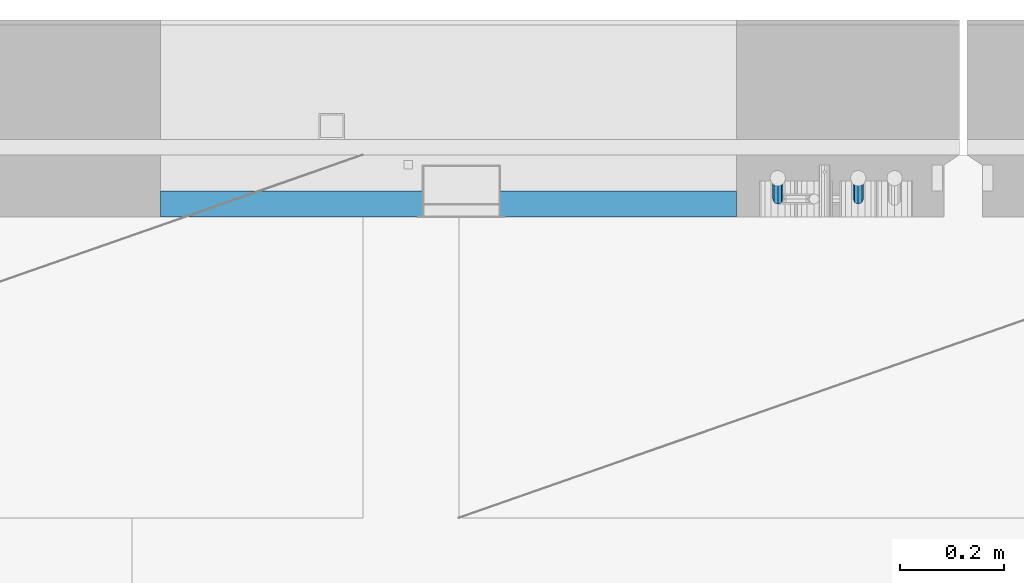
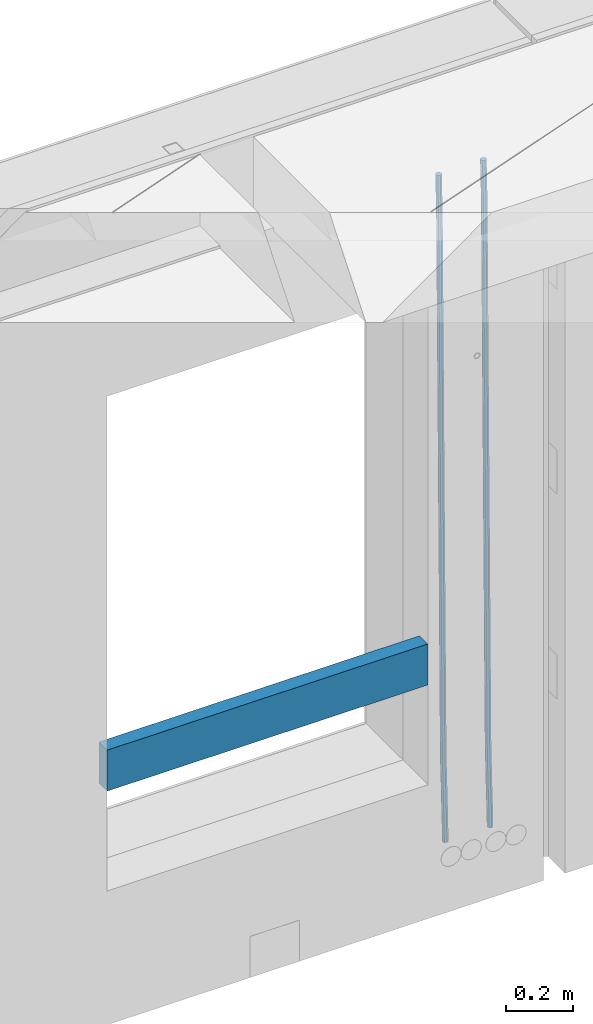
# One storey, part 112 of 341: 3 beams, 1 element without a shape of its own.
"""IFC2X3 building model written with IfcOpenShell, lengths in millimetres."""

import ifcopenshell
import ifcopenshell.guid

model = None  # the IFC model being written
_history = None  # IfcOwnerHistory: only IFC2X3 demands one
_inside = {}  # id of a spatial element -> (the spatial element, [elements in it])
_under = {}  # id of a project, library or spatial element -> (it, [spatial elements below it])
_declared = {}  # id of a project -> (the project, [libraries it declares])
_typed = {}  # id of a type object -> (the type object, [elements of that type])
_made_of = {}  # id of a material, layer set ... -> (it, [elements and type objects made of it])


def new_model(schema):
    """Start an empty IFC model of exactly this schema.

    Asked for "IFC4X3", IfcOpenShell would pick the latest addendum, in which some entities
    have other attributes; the version numbers below select the first issue.
    IFC2X3 requires an IfcOwnerHistory on every rooted entity: one is made here for all.
    """
    global model, _history
    if schema == "IFC4X3":
        model = ifcopenshell.file(schema_version=(4, 3, 0, 0))
    else:
        model = ifcopenshell.file(schema=schema)
    _inside.clear()
    _under.clear()
    _declared.clear()
    _typed.clear()
    _made_of.clear()
    _history = None
    if model.schema == "IFC2X3":
        org = make("IfcOrganization", Name="unknown")
        user = make(
            "IfcPersonAndOrganization",
            ThePerson=make("IfcPerson", FamilyName="unknown"),
            TheOrganization=org,
        )
        app = make(
            "IfcApplication",
            ApplicationDeveloper=org,
            Version="unknown",
            ApplicationFullName="unknown",
            ApplicationIdentifier="unknown",
        )
        _history = make(
            "IfcOwnerHistory",
            OwningUser=user,
            OwningApplication=app,
            ChangeAction="ADDED",
            CreationDate=0,
        )
    return model


def make(cls, **values):
    """One entity of the class cls with the attributes given. An attribute that is None is left unset."""
    return model.create_entity(
        cls, **{name: value for name, value in values.items() if value is not None}
    )


def rooted(cls, **values):
    """An entity with a GlobalId (a new one), such as an element, a storey or a relation."""
    return make(cls, GlobalId=ifcopenshell.guid.new(), OwnerHistory=_history, **values)


def si_unit(unit_type, name, prefix=None):
    """IfcSIUnit, for example si_unit("LENGTHUNIT", "METRE", prefix="MILLI")."""
    return make("IfcSIUnit", UnitType=unit_type, Prefix=prefix, Name=name)


def assignment(units):
    """IfcUnitAssignment: the units of a project."""
    return None if units is None else make("IfcUnitAssignment", Units=units)


def point(xyz):
    """IfcCartesianPoint."""
    return None if xyz is None else make("IfcCartesianPoint", Coordinates=xyz)


def direction(xyz):
    """IfcDirection."""
    return None if xyz is None else make("IfcDirection", DirectionRatios=xyz)


def frame(location, z_axis=None, x_axis=None):
    """IfcAxis2Placement3D, a coordinate frame: its origin and axes. An axis left out is left unset."""
    return make(
        "IfcAxis2Placement3D",
        Location=point(location),
        Axis=direction(z_axis),
        RefDirection=direction(x_axis),
    )


def origin_with_axes():
    """The frame at (0, 0, 0) with the z axis (0, 0, 1) and the x axis (1, 0, 0) written out."""
    return frame((0.0, 0.0, 0.0), z_axis=(0.0, 0.0, 1.0), x_axis=(1.0, 0.0, 0.0))


def place(relative_to, where):
    """IfcLocalPlacement: puts the frame where relative to a parent placement (None: the world)."""
    return make(
        "IfcLocalPlacement", PlacementRelTo=relative_to, RelativePlacement=where
    )


def context(
    kind, dimensions, precision=None, world=None, true_north=None, identifier=None
):
    """IfcGeometricRepresentationContext, for example the 3D "Model" context."""
    return make(
        "IfcGeometricRepresentationContext",
        ContextIdentifier=identifier,
        ContextType=kind,
        CoordinateSpaceDimension=dimensions,
        Precision=precision,
        WorldCoordinateSystem=world,
        TrueNorth=true_north,
    )


def subcontext(parent, identifier, kind, view, scale=None):
    """IfcGeometricRepresentationSubContext, for example "Body" below "Model"."""
    return make(
        "IfcGeometricRepresentationSubContext",
        ContextIdentifier=identifier,
        ContextType=kind,
        ParentContext=parent,
        TargetScale=scale,
        TargetView=view,
    )


def project(units=None, contexts=None):
    """IfcProject with its units and contexts."""
    return rooted(
        "IfcProject",
        Name="project",
        RepresentationContexts=contexts,
        UnitsInContext=assignment(units),
    )


def spatial(cls, under=None, at=None, **own):
    """A site, building, storey or space (cls), placed at a placement, below another one or the project."""
    s = rooted(cls, ObjectPlacement=at, **own)
    if under is not None:
        _under.setdefault(under.id(), (under, []))[1].append(s)
    return s


def faces_of(points, faces, orient=None, outer=None):
    """IfcFace entities. A face is a list of loops; a loop is a list of indices into points, from 0.

    orient and outer hold one flag for each loop. By default every Orientation is true, the
    first loop of a face is its IfcFaceOuterBound and the others are IfcFaceBound.
    """
    made = []
    for i, loops in enumerate(faces):
        bounds = []
        for j, loop in enumerate(loops):
            is_outer = j == 0 if outer is None else outer[i][j]
            bounds.append(
                make(
                    "IfcFaceOuterBound" if is_outer else "IfcFaceBound",
                    Bound=make("IfcPolyLoop", Polygon=[points[k] for k in loop]),
                    Orientation=True if orient is None else orient[i][j],
                )
            )
        made.append(make("IfcFace", Bounds=bounds))
    return made


def faceted_brep(points, faces, orient=None, outer=None, voids=None):
    """IfcFacetedBrep: a solid bounded by flat faces; with voids (closed shells), ...WithVoids."""
    shared = [point(p) for p in points]
    hull = make("IfcClosedShell", CfsFaces=faces_of(shared, faces, orient, outer))
    if voids is None:
        return make("IfcFacetedBrep", Outer=hull)
    return make(
        "IfcFacetedBrepWithVoids",
        Outer=hull,
        Voids=[
            make(cls, CfsFaces=faces_of(shared, fs, o, b)) for cls, fs, o, b in voids
        ],
    )


def shape(context_of_items, identifier, shape_type, items):
    """IfcShapeRepresentation: the items that make up one representation, for example the "Body"."""
    return make(
        "IfcShapeRepresentation",
        ContextOfItems=context_of_items,
        RepresentationIdentifier=identifier,
        RepresentationType=shape_type,
        Items=items,
    )


def material(Name=None, Category=None):
    """IfcMaterial."""
    return make("IfcMaterial", Name=Name, Category=Category)


def made_of(thing, what):
    """Note that an element or type object is made of a material, layer set ...; save() writes the relation."""
    if what is not None:
        _made_of.setdefault(what.id(), (what, []))[1].append(thing)
    return thing


def type_object(cls, material=None, **own):
    """A type object (cls), such as IfcWallType, which elements share."""
    return made_of(rooted(cls, **own), material)


def element(
    cls,
    number,
    at=None,
    inside=None,
    cuts=None,
    type_object=None,
    material=None,
    context=None,
    identifier="Body",
    shape_type=None,
    held_by="IfcProductDefinitionShape",
    body=None,
    shapes=None,
    **own,
):
    """One element of the class cls, such as IfcWall. Its Tag is "e" and its number.

    at: its placement. inside: the storey or other place that contains it. cuts: it is an
    opening in that element (IfcRelVoidsElement). A single representation is given by context,
    identifier, shape_type and body (its items); several are given by shapes. held_by: the class
    of the entity that holds the representations. save() writes the other relations.
    """
    e = rooted(cls, Tag="e%d" % number, ObjectPlacement=at, **own)
    if body is not None:
        shapes = [shape(context, identifier, shape_type, body)]
    if shapes is not None:
        e.Representation = make(held_by, Representations=shapes)
    if inside is not None:
        _inside.setdefault(inside.id(), (inside, []))[1].append(e)
    if cuts is not None:
        rooted(
            "IfcRelVoidsElement", RelatingBuildingElement=cuts, RelatedOpeningElement=e
        )
    if type_object is not None:
        _typed.setdefault(type_object.id(), (type_object, []))[1].append(e)
    return made_of(e, material)


def aggregate(whole, parts):
    """IfcRelAggregates: a whole, such as a stair, and the parts it consists of."""
    return rooted("IfcRelAggregates", RelatingObject=whole, RelatedObjects=parts)


def save(model, path):
    """Write the relations noted so far, then the file.

    IfcRelAggregates (storeys below a building ...), IfcRelContainedInSpatialStructure (elements
    in a storey), IfcRelDefinesByType, IfcRelAssociatesMaterial and IfcRelDeclares: one each for
    every whole, place, type object, material and project.
    """
    for whole, parts in _under.values():
        aggregate(whole, parts)
    for where, things in _inside.values():
        rooted(
            "IfcRelContainedInSpatialStructure",
            RelatedElements=things,
            RelatingStructure=where,
        )
    for kind, things in _typed.values():
        rooted("IfcRelDefinesByType", RelatedObjects=things, RelatingType=kind)
    for what, things in _made_of.values():
        rooted("IfcRelAssociatesMaterial", RelatedObjects=things, RelatingMaterial=what)
    for by, libraries in _declared.values():
        rooted("IfcRelDeclares", RelatingContext=by, RelatedDefinitions=libraries)
    model.write(path)


model = new_model("IFC2X3")

# Units and contexts
model_context = context("Model", 3, precision=1e-05, world=origin_with_axes())
body_context = subcontext(model_context, "Body", "Model", "MODEL_VIEW")
ifc_project = project(units=[si_unit("LENGTHUNIT", "METRE", prefix="MILLI"), si_unit("AREAUNIT", "SQUARE_METRE"), si_unit("VOLUMEUNIT", "CUBIC_METRE"), si_unit("MASSUNIT", "GRAM", prefix="KILO"), si_unit("TIMEUNIT", "SECOND"), si_unit("PLANEANGLEUNIT", "RADIAN"), si_unit("SOLIDANGLEUNIT", "STERADIAN"), si_unit("THERMODYNAMICTEMPERATUREUNIT", "DEGREE_CELSIUS"), si_unit("LUMINOUSINTENSITYUNIT", "LUMEN")], contexts=[model_context])

# Site, building, storey
site_placement = place(None, origin_with_axes())
site = spatial("IfcSite", under=ifc_project, at=site_placement, CompositionType="ELEMENT")
building_placement = place(site_placement, origin_with_axes())
building = spatial("IfcBuilding", under=site, at=building_placement, CompositionType="ELEMENT")
storey_placement = place(building_placement, origin_with_axes())
storey = spatial("IfcBuildingStorey", under=building, at=storey_placement, Name="5", CompositionType="ELEMENT", Elevation=0.0)

# Assembly, beams
assembly_placement = place(storey_placement, origin_with_axes())
assembly = element("IfcElementAssembly", 1, at=assembly_placement, inside=storey, AssemblyPlace="NOTDEFINED", PredefinedType="REINFORCEMENT_UNIT")
ifc_material_1 = material()
beam_type_1 = type_object("IfcBeamType", Name="D20", PredefinedType="NOTDEFINED")
beam_1_placement = place(assembly_placement, frame((13975.1300000039, 22654.999995444, 93989.68), z_axis=(-0.000205762999925498, 0.999642804629538, -0.0267249099901004), x_axis=(4.30000201928125e-08, 0.0267249099948059, 0.999642825806181)))
beam_1 = element("IfcBeam", 2, at=beam_1_placement, type_object=beam_type_1, material=ifc_material_1, Name="JM20", ObjectType="D20", context=body_context, shape_type="Brep", body=[
    faceted_brep([(0.0, -10.0, 0.0), (-4.19531716033816e-08, -7.07106781186667, -7.07106781187031), (60.4266690400545, -7.0710677960451, -7.07106780570757), (60.4266690441291, -9.99999998418934, 6.15546014159918e-09), (0.0, 0.0, -10.0), (60.426669036824, 1.58106558956206e-08, -9.99999999384454), (4.196772351861e-08, 7.07106781186303, -7.07106781186667), (60.4266690363438, 7.07106782768096, -7.07106780570757), (0.0, 10.0, 0.0), (60.4266690388904, 10.0000000158179, 6.15182216279209e-09), (4.196772351861e-08, 7.07106781185939, 7.07106781185939), (60.4266690429649, 7.07106782768096, 7.07106781802577), (0.0, 0.0, 10.0), (60.4266690461809, 1.58179318532348e-08, 10.0000000061555), (-4.19531716033816e-08, -7.07106781187031, 7.07106781185939), (60.4266690466611, -7.07106779605238, 7.07106781802213), (61.0378400410118, -7.07106779588503, -7.07106780564936), (60.991799419251, -9.99999998403655, 6.21366780251265e-09), (61.0569027789461, 1.5985278878361e-08, -9.99999999378269), (61.0378209396877, 7.07106782784831, -7.07106780564936), (60.9917724058905, 10.0000000159635, 6.21366780251265e-09), (60.9457317841297, 7.07106782781193, 7.0710678180767), (60.9266690461809, 1.59488990902901e-08, 10.0000000062028), (60.9457508854539, -7.07106779591413, 7.0710678180767), (61.6489592143771, -7.07106614513759, -7.06310863441468), (61.5568818710308, -9.9999984576425, 0.00735959856683621), (61.6870830769039, 1.71821739058942e-06, -9.99179257185824), (61.6489210170112, 7.07106947854481, -7.06310888312146), (61.556827851804, 10.0000015422847, 0.00735924683976918), (61.4647505084577, 7.07106922979438, 7.07782747982128), (61.4266266459163, 1.36643211590126e-06, 10.0065114172685), (61.464788705809, -7.07106639389531, 7.07782772852806), (176.543135720174, -7.07075579406956, -5.56673531796696), (176.451058376813, -9.99968810657447, 1.50373291501455), (176.581259582701, 0.000312069292704109, -8.49541925541052), (176.543097522794, 7.07137982961285, -5.56673556667374), (176.451004357587, 10.00031189336, 1.50373256329476), (176.35892701424, 7.07137958085514, 8.57420079627263), (176.320803151699, 0.000311717507429421, 11.5028847337162), (176.358965211621, -7.07075604281999, 8.57420104497578), (177.098753836006, -7.07075429323595, -5.55949898843028), (176.98362511232, -9.99968666800123, 1.510669025065), (177.146421932586, 0.000313595905026887, -8.48805862247536), (177.098706077581, 7.07138133041735, -5.55949936166144), (176.983557571715, 10.0003133318824, 1.51066849724157), (176.868428848029, 7.07138095712435, 8.58083651073321), (176.820760751449, 0.000313067976094317, 11.5093961447819), (176.868476606425, -7.07075466652896, 8.58083688396073), (177.654312950661, -7.07075204110879, -5.54863964998367), (177.516135294456, -9.99968450931192, 1.52107783331303), (177.711524267797, 0.000315886711177882, -8.47701274570863), (177.654255632195, 7.07138358250813, -5.54864021007961), (177.516054233929, 10.0003154905207, 1.5210770412159), (177.377876577739, 7.0713830223176, 8.59079452451624), (177.320665260588, 0.000315094497636892, 11.5191676202448), (177.377933896176, -7.07075260129932, 8.59079508461218), (299.436796249574, -7.07025836271714, -3.1681962331204), (299.298618593355, -9.99919083092027, 3.90152125031091), (299.494007566798, 0.000809565110102994, -6.09656932889993), (299.436738931283, 7.07187726089978, -3.16819679320906), (299.298537533061, 10.0008091689197, 3.90152045822106), (299.160359876842, 7.07187670072017, 10.9712379416487), (299.103148559603, 0.000808772889286047, 13.8996110374392), (299.160417195119, -7.07025892290039, 10.9712385017483), (299.98743051647, -7.07025613056248, -3.15743315966392), (299.971788958996, -9.99918809853989, 3.91467979818117), (299.993912075952, 0.000811591617093654, -6.08679785393178), (299.987423933868, 7.07187949325817, -3.1574327280432), (299.971753863239, 10.0008119014747, 3.91467990454839), (299.95611230444, 7.07187992653053, 10.9867922621015), (299.949630744944, 0.000812204350950196, 13.9161569563694), (299.956118887014, -7.07025569729012, 10.9867918304735), (300.538107039494, -7.07025785017686, -3.16575821840888), (300.644985195438, -9.99919020432935, 3.90450175465594), (300.493854948218, 0.000810030429420294, -6.09435592770024), (300.538151196495, 7.071877773491, -3.16575855385963), (300.645047642858, 10.0008097955724, 3.90450128024895), (300.751925798773, 7.07187744142357, 10.9747612533101), (300.796177890064, 0.000809560813650023, 13.9033589625978), (300.751881641787, -7.07025818224065, 10.9747615887682), (2293.36490490142, -7.07648090940347, -33.2930642912361), (2293.47178305736, -10.0054132635523, -26.2228043181785), (2293.32065281013, -0.00541302880083094, -36.2216620005347), (2293.36494905842, 7.06565471425711, -33.2930646266868), (2293.47184550477, 9.99458673634581, -26.2228047925819), (2293.57872366071, 7.06565438219332, -19.1525448195243), (2293.62297575199, -0.00541349841296324, -16.2239471102366), (2293.57867950371, -7.0764812414709, -19.1525444840736), (2294.0658245362, -7.07648309818615, -33.3036607065333), (2294.05312277409, -10.0054150789219, -26.2315929392535), (2294.10928714235, -0.00541549149056664, -36.2335844756526), (2294.15805078732, 7.06565223761572, -33.3050546393533), (2294.18355038921, 9.99458451388637, -26.2335642579346), (2294.17084862708, 7.06565253314329, -19.1614964906439), (2294.12738602093, -0.00541507354500936, -16.2315727215355), (2294.07862237596, -7.07648280265857, -19.1601025578348), (2294.76670261032, -7.08562269121467, -33.294332712383), (2294.63442802057, -10.0129954178956, -26.2238563411993), (2294.89787471293, -0.0156988342423574, -36.2230891548279), (2294.95110548967, 7.05531064255774, -33.2944998654275), (2294.89521307347, 9.98530428734011, -26.2240927312887), (2294.76293848372, 7.0579315606592, -19.1536163601049), (2294.63176638114, -0.0119922963167483, -16.2248599176673), (2294.57853560438, -7.08300177311321, -19.1534492070678), (2316.52657204497, -7.36937582653991, -33.0047303660212), (2316.39429745522, -10.2967485532172, -25.9342539948302), (2316.65774414754, -0.299451969567599, -35.9334868084661), (2316.7109749243, 6.7715575072325, -33.0048975190657), (2316.65508250811, 9.70155115201487, -25.9344903849269), (2316.52280791836, 6.7741784253376, -18.8640140137468), (2316.39163581574, -0.295745431634714, -15.9352575713092), (2316.33840503903, -7.36675490843481, -18.863846860706), (2317.16202064224, -7.37766220584308, -32.9962731735213), (2317.05438744847, -10.3053562613532, -25.9254688497131), (2317.23607125619, -0.306993473008333, -35.925789846493), (2317.23316144495, 6.76474808850253, -32.9979477328052), (2317.15499573652, 9.6950321815566, -25.9278370341635), (2317.04736254275, 6.7673381260538, -18.8570327103698), (2316.97331192881, -0.303330606784584, -15.9275160373909), (2316.97622174003, -7.37507216829545, -18.8553581510787), (2317.79752306276, -7.37578610372293, -32.9880110666527), (2317.71453320107, -10.3033876998124, -25.9168792378296), (2317.81444760226, -0.305295583297266, -35.918287695793), (2317.75539265381, 6.76628640723357, -32.9911928173897), (2317.65495180529, 9.69652304524061, -25.9213789128698), (2317.5719619436, 6.76892144914746, -18.8502470840467), (2317.55503740412, -0.301569071270933, -15.9199704549137), (2317.61409235255, -7.3731510618054, -18.847065333317), (2417.8183084176, -7.07752398473531, -31.6906369377139), (2417.73531855589, -10.0051255808248, -24.6195051088798), (2417.83523295709, -0.007033464313281, -34.6209135668432), (2417.77617800863, 7.06454852621755, -31.6938186884508), (2417.67573716014, 9.99478516423187, -24.6240047839383), (2417.59274729842, 7.06718356813872, -17.5528729551006), (2417.57582275895, -0.00330695228694822, -14.6225963259749), (2417.6348777074, -7.07488894281778, -17.5496912043673)], [[[0, 1, 2, 3]], [[1, 4, 5, 2]], [[4, 6, 7, 5]], [[6, 8, 9, 7]], [[8, 10, 11, 9]], [[10, 12, 13, 11]], [[12, 14, 15, 13]], [[14, 0, 3, 15]], [[14, 12, 10, 8, 6, 4, 1, 0]], [[3, 2, 16, 17]], [[2, 5, 18, 16]], [[5, 7, 19, 18]], [[7, 9, 20, 19]], [[9, 11, 21, 20]], [[11, 13, 22, 21]], [[13, 15, 23, 22]], [[15, 3, 17, 23]], [[17, 16, 24, 25]], [[16, 18, 26, 24]], [[18, 19, 27, 26]], [[19, 20, 28, 27]], [[20, 21, 29, 28]], [[21, 22, 30, 29]], [[22, 23, 31, 30]], [[23, 17, 25, 31]], [[25, 24, 32, 33]], [[24, 26, 34, 32]], [[26, 27, 35, 34]], [[27, 28, 36, 35]], [[28, 29, 37, 36]], [[29, 30, 38, 37]], [[30, 31, 39, 38]], [[31, 25, 33, 39]], [[33, 32, 40, 41]], [[32, 34, 42, 40]], [[34, 35, 43, 42]], [[35, 36, 44, 43]], [[36, 37, 45, 44]], [[37, 38, 46, 45]], [[38, 39, 47, 46]], [[39, 33, 41, 47]], [[41, 40, 48, 49]], [[40, 42, 50, 48]], [[42, 43, 51, 50]], [[43, 44, 52, 51]], [[44, 45, 53, 52]], [[45, 46, 54, 53]], [[46, 47, 55, 54]], [[47, 41, 49, 55]], [[49, 48, 56, 57]], [[48, 50, 58, 56]], [[50, 51, 59, 58]], [[51, 52, 60, 59]], [[52, 53, 61, 60]], [[53, 54, 62, 61]], [[54, 55, 63, 62]], [[55, 49, 57, 63]], [[57, 56, 64, 65]], [[56, 58, 66, 64]], [[58, 59, 67, 66]], [[59, 60, 68, 67]], [[60, 61, 69, 68]], [[61, 62, 70, 69]], [[62, 63, 71, 70]], [[63, 57, 65, 71]], [[65, 64, 72, 73]], [[64, 66, 74, 72]], [[66, 67, 75, 74]], [[67, 68, 76, 75]], [[68, 69, 77, 76]], [[69, 70, 78, 77]], [[70, 71, 79, 78]], [[71, 65, 73, 79]], [[73, 72, 80, 81]], [[72, 74, 82, 80]], [[74, 75, 83, 82]], [[75, 76, 84, 83]], [[76, 77, 85, 84]], [[77, 78, 86, 85]], [[78, 79, 87, 86]], [[79, 73, 81, 87]], [[81, 80, 88, 89]], [[80, 82, 90, 88]], [[82, 83, 91, 90]], [[83, 84, 92, 91]], [[84, 85, 93, 92]], [[85, 86, 94, 93]], [[86, 87, 95, 94]], [[87, 81, 89, 95]], [[89, 88, 96, 97]], [[88, 90, 98, 96]], [[90, 91, 99, 98]], [[91, 92, 100, 99]], [[92, 93, 101, 100]], [[93, 94, 102, 101]], [[94, 95, 103, 102]], [[95, 89, 97, 103]], [[97, 96, 104, 105]], [[96, 98, 106, 104]], [[98, 99, 107, 106]], [[99, 100, 108, 107]], [[100, 101, 109, 108]], [[101, 102, 110, 109]], [[102, 103, 111, 110]], [[103, 97, 105, 111]], [[105, 104, 112, 113]], [[104, 106, 114, 112]], [[106, 107, 115, 114]], [[107, 108, 116, 115]], [[108, 109, 117, 116]], [[109, 110, 118, 117]], [[110, 111, 119, 118]], [[111, 105, 113, 119]], [[113, 112, 120, 121]], [[112, 114, 122, 120]], [[114, 115, 123, 122]], [[115, 116, 124, 123]], [[116, 117, 125, 124]], [[117, 118, 126, 125]], [[118, 119, 127, 126]], [[119, 113, 121, 127]], [[121, 120, 128, 129]], [[120, 122, 130, 128]], [[122, 123, 131, 130]], [[123, 124, 132, 131]], [[124, 125, 133, 132]], [[125, 126, 134, 133]], [[126, 127, 135, 134]], [[127, 121, 129, 135]], [[130, 131, 132, 133, 134, 135, 129, 128]]]),
])
beam_2_placement = place(assembly_placement, frame((14130.1300000039, 22654.999995444, 93989.68), z_axis=(-0.000205762999925498, 0.999642804629538, -0.0267249099901004), x_axis=(4.30000201928125e-08, 0.0267249099948059, 0.999642825806181)))
beam_2 = element("IfcBeam", 3, at=beam_2_placement, type_object=beam_type_1, material=ifc_material_1, Name="JM20", ObjectType="D20", context=body_context, shape_type="Brep", body=[
    faceted_brep([(0.0, -10.0, 0.0), (-4.19531716033816e-08, -7.07106781186667, -7.07106781187031), (60.3573713480873, -7.07106779909736, -7.07106780570757), (60.3573713520018, -9.99999998723251, 6.15546014159918e-09), (0.0, 0.0, -10.0), (60.357371345206, 1.27656676340848e-08, -9.99999999384454), (4.196772351861e-08, 7.07106781186303, -7.07106781186667), (60.3573713450896, 7.07106782463052, -7.07106780570757), (0.0, 10.0, 0.0), (60.3573713477817, 10.0000000127657, 6.15546014159918e-09), (4.196772351861e-08, 7.07106781185939, 7.07106781185939), (60.3573713517108, 7.07106782463234, 7.07106781802213), (0.0, 0.0, 10.0), (60.3573713545775, 1.27656676340848e-08, 10.0000000061555), (-4.19531716033816e-08, -7.07106781187031, 7.07106781185939), (60.3573713546939, -7.07106779909736, 7.07106781801849), (61.0868506554398, -7.07106779894457, -7.07106780563845), (60.991799419251, -9.99999998403655, 6.21366780251265e-09), (61.126200470535, 1.29293766804039e-08, -9.99999999376814), (61.0868120605446, 7.07106782478695, -7.07106780563481), (60.9917724058905, 10.0000000159635, 6.21366780251265e-09), (60.8967211696581, 7.07106782474875, 7.0710678180767), (60.8573713545775, 1.2872988008894e-08, 10.0000000062064), (60.8967597645533, -7.07106779898459, 7.07106781807306), (61.8160664163588, -7.07106381821541, -7.05146081959901), (61.6260258432449, -9.99999652498445, 0.017052570146916), (61.8947518331115, 4.20838841819204e-06, -9.97933536109849), (61.8159892434924, 7.07107180530511, -7.05146185687408), (61.6259167043172, 10.0000034747191, 0.0170511032192735), (61.4358761312033, 7.07107076795, 7.08556449295429), (61.3571907144506, 2.74134617939126e-06, 10.0134390344538), (61.4359533040697, -7.07106485557051, 7.08556553022936), (146.602571042196, -7.07060097563044, -4.77174073989954), (146.412530469053, -9.99953368240131, 2.29677264984275), (146.681256458905, 0.000467050971565186, -7.69961528139902), (146.602493869315, 7.07153464789008, -4.77174177717461), (146.41242133014, 10.0004663173004, 2.29677118291511), (146.222380757012, 7.07153361053315, 9.36528457265376), (146.143695340288, 0.000465583929326385, 12.2931591141532), (146.222457929893, -7.07060201298918, 9.36528560992883), (147.126399134097, -7.07059811609543, -4.75765617037177), (146.994344415885, -9.99953050632757, 2.31241632972888), (147.181075818822, 0.000469779444756568, -7.68617625315164), (147.126345609664, 7.07153750755242, -4.75765657179363), (146.994268720911, 10.0004694935578, 2.31241576203684), (146.8622140027, 7.07153710333114, 9.38248826213749), (146.807537317989, 0.000469207789137727, 12.3110083449137), (146.862267527133, -7.07059852031853, 9.38248866355571), (147.650387802729, -7.07059700935133, -4.75216798895053), (147.576336714686, -9.99952927706909, 2.3185120327762), (147.681048395651, 0.000470835462692776, -7.68093961279374), (147.650357933962, 7.07153861434745, -4.75216814260784), (147.576294473896, 10.0004707228873, 2.31851181546881), (147.502243385854, 7.07153845517132, 9.3891918371919), (147.471582792903, 0.000470610355478129, 12.3179634610351), (147.502273254577, -7.07059716852928, 9.38919199084557), (299.417920105596, -7.07027645305425, -3.16257683766162), (299.343869017583, -9.99920872077018, 3.90810318405784), (299.448580698547, 0.000791391765233129, -6.09134846150846), (299.417890236859, 7.07185917064635, -3.16257699131893), (299.343826776778, 10.0007912791862, 3.90810296676136), (299.26977568875, 7.07185901147022, 10.9787829884772), (299.239115095814, 0.000791166652561515, 13.907554612324), (299.269805557487, -7.07027661222673, 10.9787831421345), (299.955350135861, -7.07027531791755, -3.15694787336906), (299.971788958996, -9.99918809853989, 3.91467979818117), (299.94855327539, 0.000792447781350347, -6.08611182115419), (299.955357283936, 7.07186030585945, -3.15694763931606), (299.971753863239, 10.0008119014747, 3.91467990454839), (299.988192686345, 7.07186052887664, 10.9863075840512), (299.994989546802, 0.000792763177742017, 13.91547153184), (299.988185538285, -7.07027509490035, 10.9863073500019), (300.49274823608, -7.07027699627724, -3.16507219004052), (300.599626390831, -9.99920935543742, 3.90518778107071), (300.448496147656, 0.000790886399045121, -6.09366989441332), (300.492792398771, 7.07185862738334, -3.1650725155705), (300.599688846312, 10.0007906444662, 3.90518732069904), (300.706567001063, 7.07185828530783, 10.9754472918103), (300.750819089502, 0.000790402629718301, 13.9040449961867), (300.706522838373, -7.07027733835457, 10.9754476173403), (2293.36490490142, -7.07648090940347, -33.2930642912361), (2293.47178305736, -10.0054132635523, -26.2228043181785), (2293.32065281013, -0.00541302880083094, -36.2216620005347), (2293.36494905842, 7.06565471425711, -33.2930646266868), (2293.47184550477, 9.99458673634581, -26.2228047925819), (2293.57872366071, 7.06565438219332, -19.1525448195243), (2293.62297575199, -0.00541349841296324, -16.2239471102366), (2293.57867950371, -7.0764812414709, -19.1525444840736), (2294.0658245362, -7.07648309818615, -33.3036607065333), (2294.05312277409, -10.0054150789219, -26.2315929392535), (2294.10928714235, -0.00541549149056664, -36.2335844756526), (2294.15805078732, 7.06565223761572, -33.3050546393533), (2294.18355038921, 9.99458451388637, -26.2335642579346), (2294.17084862708, 7.06565253314329, -19.1614964906439), (2294.12738602093, -0.00541507354500936, -16.2315727215355), (2294.07862237596, -7.07648280265857, -19.1601025578348), (2294.76670261032, -7.08562269121467, -33.294332712383), (2294.63442802057, -10.0129954178956, -26.2238563411993), (2294.89787471293, -0.0156988342423574, -36.2230891548279), (2294.95110548967, 7.05531064255774, -33.2944998654275), (2294.89521307347, 9.98530428734011, -26.2240927312887), (2294.76293848372, 7.0579315606592, -19.1536163601049), (2294.63176638114, -0.0119922963167483, -16.2248599176673), (2294.57853560438, -7.08300177311321, -19.1534492070678), (2316.52657204497, -7.36937582653991, -33.0047303660212), (2316.39429745522, -10.2967485532172, -25.9342539948302), (2316.65774414754, -0.299451969567599, -35.9334868084661), (2316.7109749243, 6.7715575072325, -33.0048975190657), (2316.65508250811, 9.70155115201487, -25.9344903849269), (2316.52280791836, 6.7741784253376, -18.8640140137468), (2316.39163581574, -0.295745431634714, -15.9352575713092), (2316.33840503903, -7.36675490843481, -18.863846860706), (2317.16202064224, -7.37766220584308, -32.9962731735213), (2317.05438744847, -10.3053562613532, -25.9254688497131), (2317.23607125619, -0.306993473008333, -35.925789846493), (2317.23316144495, 6.76474808850253, -32.9979477328052), (2317.15499573652, 9.6950321815566, -25.9278370341635), (2317.04736254275, 6.7673381260538, -18.8570327103698), (2316.97331192881, -0.303330606784584, -15.9275160373909), (2316.97622174003, -7.37507216829545, -18.8553581510787), (2317.79752306276, -7.37578610372293, -32.9880110666527), (2317.71453320107, -10.3033876998124, -25.9168792378296), (2317.81444760226, -0.305295583297266, -35.918287695793), (2317.75539265381, 6.76628640723357, -32.9911928173897), (2317.65495180529, 9.69652304524061, -25.9213789128698), (2317.5719619436, 6.76892144914746, -18.8502470840467), (2317.55503740412, -0.301569071270933, -15.9199704549137), (2317.61409235255, -7.3731510618054, -18.847065333317), (2417.8183084176, -7.07752398473531, -31.6906369377139), (2417.73531855589, -10.0051255808248, -24.6195051088798), (2417.83523295709, -0.007033464313281, -34.6209135668432), (2417.77617800863, 7.06454852621755, -31.6938186884508), (2417.67573716014, 9.99478516423187, -24.6240047839383), (2417.59274729842, 7.06718356813872, -17.5528729551006), (2417.57582275895, -0.00330695228694822, -14.6225963259749), (2417.6348777074, -7.07488894281778, -17.5496912043673)], [[[0, 1, 2, 3]], [[1, 4, 5, 2]], [[4, 6, 7, 5]], [[6, 8, 9, 7]], [[8, 10, 11, 9]], [[10, 12, 13, 11]], [[12, 14, 15, 13]], [[14, 0, 3, 15]], [[14, 12, 10, 8, 6, 4, 1, 0]], [[3, 2, 16, 17]], [[2, 5, 18, 16]], [[5, 7, 19, 18]], [[7, 9, 20, 19]], [[9, 11, 21, 20]], [[11, 13, 22, 21]], [[13, 15, 23, 22]], [[15, 3, 17, 23]], [[17, 16, 24, 25]], [[16, 18, 26, 24]], [[18, 19, 27, 26]], [[19, 20, 28, 27]], [[20, 21, 29, 28]], [[21, 22, 30, 29]], [[22, 23, 31, 30]], [[23, 17, 25, 31]], [[25, 24, 32, 33]], [[24, 26, 34, 32]], [[26, 27, 35, 34]], [[27, 28, 36, 35]], [[28, 29, 37, 36]], [[29, 30, 38, 37]], [[30, 31, 39, 38]], [[31, 25, 33, 39]], [[33, 32, 40, 41]], [[32, 34, 42, 40]], [[34, 35, 43, 42]], [[35, 36, 44, 43]], [[36, 37, 45, 44]], [[37, 38, 46, 45]], [[38, 39, 47, 46]], [[39, 33, 41, 47]], [[41, 40, 48, 49]], [[40, 42, 50, 48]], [[42, 43, 51, 50]], [[43, 44, 52, 51]], [[44, 45, 53, 52]], [[45, 46, 54, 53]], [[46, 47, 55, 54]], [[47, 41, 49, 55]], [[49, 48, 56, 57]], [[48, 50, 58, 56]], [[50, 51, 59, 58]], [[51, 52, 60, 59]], [[52, 53, 61, 60]], [[53, 54, 62, 61]], [[54, 55, 63, 62]], [[55, 49, 57, 63]], [[57, 56, 64, 65]], [[56, 58, 66, 64]], [[58, 59, 67, 66]], [[59, 60, 68, 67]], [[60, 61, 69, 68]], [[61, 62, 70, 69]], [[62, 63, 71, 70]], [[63, 57, 65, 71]], [[65, 64, 72, 73]], [[64, 66, 74, 72]], [[66, 67, 75, 74]], [[67, 68, 76, 75]], [[68, 69, 77, 76]], [[69, 70, 78, 77]], [[70, 71, 79, 78]], [[71, 65, 73, 79]], [[73, 72, 80, 81]], [[72, 74, 82, 80]], [[74, 75, 83, 82]], [[75, 76, 84, 83]], [[76, 77, 85, 84]], [[77, 78, 86, 85]], [[78, 79, 87, 86]], [[79, 73, 81, 87]], [[81, 80, 88, 89]], [[80, 82, 90, 88]], [[82, 83, 91, 90]], [[83, 84, 92, 91]], [[84, 85, 93, 92]], [[85, 86, 94, 93]], [[86, 87, 95, 94]], [[87, 81, 89, 95]], [[89, 88, 96, 97]], [[88, 90, 98, 96]], [[90, 91, 99, 98]], [[91, 92, 100, 99]], [[92, 93, 101, 100]], [[93, 94, 102, 101]], [[94, 95, 103, 102]], [[95, 89, 97, 103]], [[97, 96, 104, 105]], [[96, 98, 106, 104]], [[98, 99, 107, 106]], [[99, 100, 108, 107]], [[100, 101, 109, 108]], [[101, 102, 110, 109]], [[102, 103, 111, 110]], [[103, 97, 105, 111]], [[105, 104, 112, 113]], [[104, 106, 114, 112]], [[106, 107, 115, 114]], [[107, 108, 116, 115]], [[108, 109, 117, 116]], [[109, 110, 118, 117]], [[110, 111, 119, 118]], [[111, 105, 113, 119]], [[113, 112, 120, 121]], [[112, 114, 122, 120]], [[114, 115, 123, 122]], [[115, 116, 124, 123]], [[116, 117, 125, 124]], [[117, 118, 126, 125]], [[118, 119, 127, 126]], [[119, 113, 121, 127]], [[121, 120, 128, 129]], [[120, 122, 130, 128]], [[122, 123, 131, 130]], [[123, 124, 132, 131]], [[124, 125, 133, 132]], [[125, 126, 134, 133]], [[126, 127, 135, 134]], [[127, 121, 129, 135]], [[130, 131, 132, 133, 134, 135, 129, 128]]]),
])
ifc_material_2 = material(Name="TIMBER/T24")
beam_type_2 = type_object("IfcBeamType", PredefinedType="NOTDEFINED")
beam_3_placement = place(assembly_placement, frame((13895.0002989913, 22644.9998418812, 94685.0), z_axis=(0.0, 0.0, 1.0), x_axis=(-1.0, 3.00000001838171e-08, 0.0)))
beam_3 = element("IfcBeam", 4, at=beam_3_placement, type_object=beam_type_2, material=ifc_material_2, context=body_context, shape_type="Brep", body=[
    faceted_brep([(-3.63797880709171e-12, 24.9999999999964, -75.0), (-3.63797880709171e-12, 24.9999999999964, 75.0), (1110.0, 24.9999999999964, 75.0), (1110.0, 24.9999999999964, -75.0), (0.0, -25.0000000000073, 75.0), (1110.0, -25.0000000000073, 75.0), (0.0, -25.0000000000073, -75.0), (1110.0, -25.0000000000073, -75.0)], [[[0, 1, 2, 3]], [[1, 4, 5, 2]], [[4, 6, 7, 5]], [[6, 0, 3, 7]], [[5, 7, 3, 2]], [[6, 4, 1, 0]]]),
])
aggregate(assembly, [beam_1, beam_2, beam_3])

save(model, "model.ifc")
